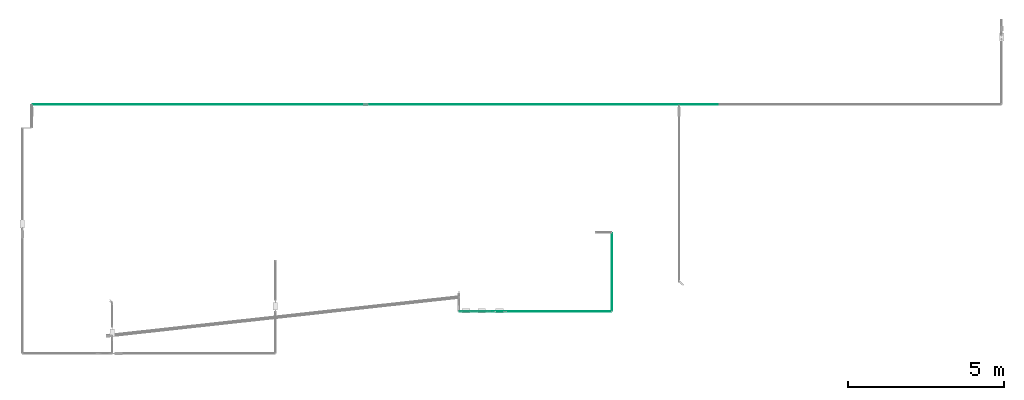
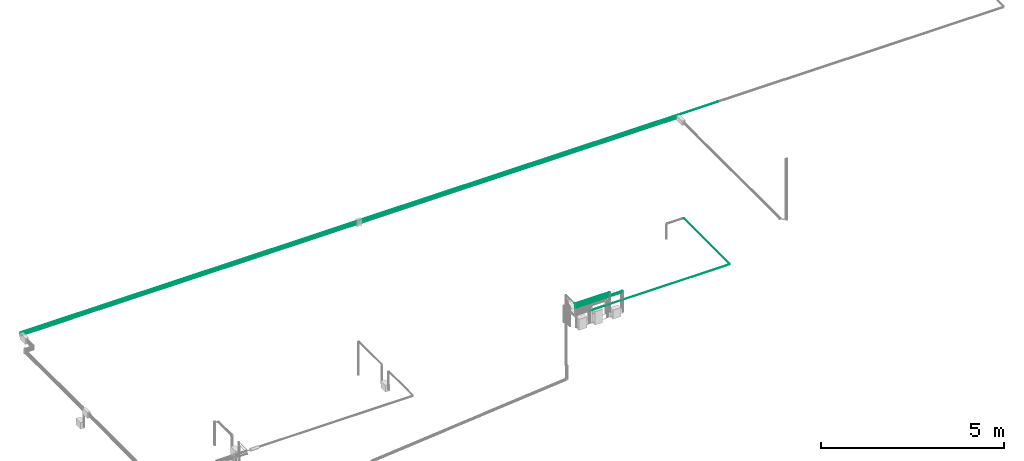
# One storey, part 6 of 45: 9 flow segments.
"""IFC2X3 building model written with IfcOpenShell, lengths in millimetres."""

from ifc_helpers import new_model, entity, si_unit, converted_unit, derived_unit, direction, frame, origin, origin_2d_with_axis, place, context, subcontext, project, spatial, circle, extrude, type_object, element, save


model = new_model("IFC2X3")

# Units and contexts
model_context = context("Model", 3, precision=0.01, world=origin(), true_north=direction((6.12303176911189e-17, 1.0)))
body_context = subcontext(model_context, "Body", "Model", "MODEL_VIEW")
ifc_project = project(units=[si_unit("LENGTHUNIT", "METRE", prefix="MILLI"), si_unit("AREAUNIT", "SQUARE_METRE"), si_unit("VOLUMEUNIT", "CUBIC_METRE"), converted_unit("PLANEANGLEUNIT", "DEGREE", entity("IfcRatioMeasure", 0.0174532925199433), si_unit("PLANEANGLEUNIT", "RADIAN"), dimensions=[0, 0, 0, 0, 0, 0, 0]), si_unit("MASSUNIT", "GRAM", prefix="KILO"), derived_unit("MASSDENSITYUNIT", [(si_unit("MASSUNIT", "GRAM", prefix="KILO"), 1), (si_unit("LENGTHUNIT", "METRE"), -3)]), derived_unit("MOMENTOFINERTIAUNIT", [(si_unit("LENGTHUNIT", "METRE"), 4)]), si_unit("TIMEUNIT", "SECOND"), si_unit("FREQUENCYUNIT", "HERTZ"), si_unit("THERMODYNAMICTEMPERATUREUNIT", "DEGREE_CELSIUS"), derived_unit("THERMALTRANSMITTANCEUNIT", [(si_unit("MASSUNIT", "GRAM", prefix="KILO"), 1), (si_unit("THERMODYNAMICTEMPERATUREUNIT", "KELVIN"), -1), (si_unit("TIMEUNIT", "SECOND"), -3)]), derived_unit("VOLUMETRICFLOWRATEUNIT", [(si_unit("LENGTHUNIT", "METRE"), 3), (si_unit("TIMEUNIT", "SECOND"), -1)]), derived_unit("MASSFLOWRATEUNIT", [(si_unit("MASSUNIT", "GRAM", prefix="KILO"), 1), (si_unit("TIMEUNIT", "SECOND"), -1)]), derived_unit("ROTATIONALFREQUENCYUNIT", [(si_unit("TIMEUNIT", "SECOND"), -1)]), si_unit("ELECTRICCURRENTUNIT", "AMPERE"), si_unit("ELECTRICVOLTAGEUNIT", "VOLT"), si_unit("POWERUNIT", "WATT"), si_unit("FORCEUNIT", "NEWTON", prefix="KILO"), si_unit("ILLUMINANCEUNIT", "LUX"), si_unit("LUMINOUSFLUXUNIT", "LUMEN"), si_unit("LUMINOUSINTENSITYUNIT", "CANDELA"), derived_unit("USERDEFINED", [(si_unit("MASSUNIT", "GRAM", prefix="KILO"), -1), (si_unit("LENGTHUNIT", "METRE"), -2), (si_unit("TIMEUNIT", "SECOND"), 3), (si_unit("LUMINOUSFLUXUNIT", "LUMEN"), 1)]), derived_unit("LINEARVELOCITYUNIT", [(si_unit("LENGTHUNIT", "METRE"), 1), (si_unit("TIMEUNIT", "SECOND"), -1)]), si_unit("PRESSUREUNIT", "PASCAL"), derived_unit("USERDEFINED", [(si_unit("LENGTHUNIT", "METRE"), -2), (si_unit("MASSUNIT", "GRAM", prefix="KILO"), 1), (si_unit("TIMEUNIT", "SECOND"), -2)]), derived_unit("LINEARFORCEUNIT", [(si_unit("MASSUNIT", "GRAM", prefix="KILO"), 1), (si_unit("LENGTHUNIT", "METRE"), 1), (si_unit("TIMEUNIT", "SECOND"), -2), (si_unit("LENGTHUNIT", "METRE"), -1)]), derived_unit("PLANARFORCEUNIT", [(si_unit("MASSUNIT", "GRAM", prefix="KILO"), 1), (si_unit("LENGTHUNIT", "METRE"), 1), (si_unit("TIMEUNIT", "SECOND"), -2), (si_unit("LENGTHUNIT", "METRE"), -2)])], contexts=[model_context])

# Site, building, storey
site_placement = place(None, frame((-24836.06, 8968.75, 0.0)))
site = spatial("IfcSite", under=ifc_project, at=site_placement, CompositionType="ELEMENT")
building_placement = place(site_placement, origin())
building = spatial("IfcBuilding", under=site, at=building_placement, CompositionType="ELEMENT")
storey_placement = place(building_placement, frame((0.0, 0.0, -4200.0)))
storey = spatial("IfcBuildingStorey", under=building, at=storey_placement, CompositionType="ELEMENT", Elevation=-4200.0)

# Flow segments
pipe_segment_type = type_object("IfcPipeSegmentType", PredefinedType="NOTDEFINED")
flow_segment_1_placement = place(storey_placement, frame((80771.15, -7593.52, 2345.23)))
element("IfcFlowSegment", 1, at=flow_segment_1_placement, inside=storey, type_object=pipe_segment_type, context=body_context, shape_type="SweptSolid", body=[
    extrude(circle(Radius=3.175, at=origin_2d_with_axis()), frame((0.0, 4.77, 4.77), z_axis=(1.0, 0.0, 0.0), x_axis=(0.0, -1.0, 0.0)), (0.0, 0.0, 1.0), 1025.22825500751),
])
flow_segment_2_placement = place(storey_placement, frame((80771.15, -7593.52, 2395.23)))
element("IfcFlowSegment", 2, at=flow_segment_2_placement, inside=storey, type_object=pipe_segment_type, context=body_context, shape_type="SweptSolid", body=[
    extrude(circle(Radius=3.175, at=origin_2d_with_axis()), frame((0.0, 4.77, 4.77), z_axis=(1.0, 0.0, 0.0), x_axis=(0.0, -1.0, 0.0)), (0.0, 0.0, 1.0), 1075.22825500752),
])
flow_segment_3_placement = place(storey_placement, frame((80771.15, -7591.94, 2246.81)))
element("IfcFlowSegment", 3, at=flow_segment_3_placement, inside=storey, type_object=pipe_segment_type, context=body_context, shape_type="SweptSolid", body=[
    extrude(circle(Radius=1.59, at=origin_2d_with_axis()), frame((0.0, 3.19, 3.19), z_axis=(1.0, 0.0, 0.0), x_axis=(0.0, 1.0, 0.0)), (0.0, 0.0, 1.0), 1425.22825500751),
])
flow_segment_4_placement = place(storey_placement, frame((81226.32, -7596.7, 1992.05)))
element("IfcFlowSegment", 4, at=flow_segment_4_placement, inside=storey, type_object=pipe_segment_type, context=body_context, shape_type="SweptSolid", body=[
    extrude(circle(Radius=6.35, at=origin_2d_with_axis()), frame((0.0, 7.95, 7.95), z_axis=(1.0, 0.0, 0.0), x_axis=(0.0, -1.0, 0.0)), (0.0, 0.0, 1.0), 4394.03455575114),
])
flow_segment_5_placement = place(storey_placement, frame((80771.15, -7591.94, 2296.81)))
element("IfcFlowSegment", 5, at=flow_segment_5_placement, inside=storey, type_object=pipe_segment_type, context=body_context, shape_type="SweptSolid", body=[
    extrude(circle(Radius=1.59, at=origin_2d_with_axis()), frame((0.0, 3.19, 3.19), z_axis=(1.0, 0.0, 0.0), x_axis=(0.0, -1.0, 0.0)), (0.0, 0.0, 1.0), 1475.22825500751),
])
flow_segment_6_placement = place(storey_placement, frame((85637.81, -7563.35, 1992.05)))
element("IfcFlowSegment", 6, at=flow_segment_6_placement, inside=storey, type_object=pipe_segment_type, context=body_context, shape_type="SweptSolid", body=[
    extrude(circle(Radius=6.35, at=origin_2d_with_axis()), frame((7.95, 0.0, 7.95), z_axis=(0.0, 1.0, 0.0), x_axis=(1.0, 0.0, 0.0)), (0.0, 0.0, 1.0), 2483.85107232868),
])
flow_segment_7_placement = place(storey_placement, frame((67096.65, -974.87, 2188.88)))
element("IfcFlowSegment", 7, at=flow_segment_7_placement, inside=storey, type_object=pipe_segment_type, context=body_context, shape_type="SweptSolid", body=[
    extrude(circle(Radius=9.525, at=origin_2d_with_axis()), frame((0.0, 11.12, 11.12), z_axis=(1.0, 0.0, 0.0), x_axis=(0.0, 1.0, 0.0)), (0.0, 0.0, 1.0), 22002.5039196189),
])
for number, where in (
    (8, (67096.65, -968.52, 2145.23)),
    (9, (67096.65, -968.52, 2095.23)),
):
    element("IfcFlowSegment", number, at=place(storey_placement, frame(where)), inside=storey, type_object=pipe_segment_type, context=body_context, shape_type="SweptSolid", body=[
        extrude(circle(Radius=3.175, at=origin_2d_with_axis()), frame((0.0, 4.77, 4.77), z_axis=(1.0, 0.0, 0.0), x_axis=(0.0, -1.0, 0.0)), (0.0, 0.0, 1.0), 20674.2000241199),
    ])

save(model, "model.ifc")
